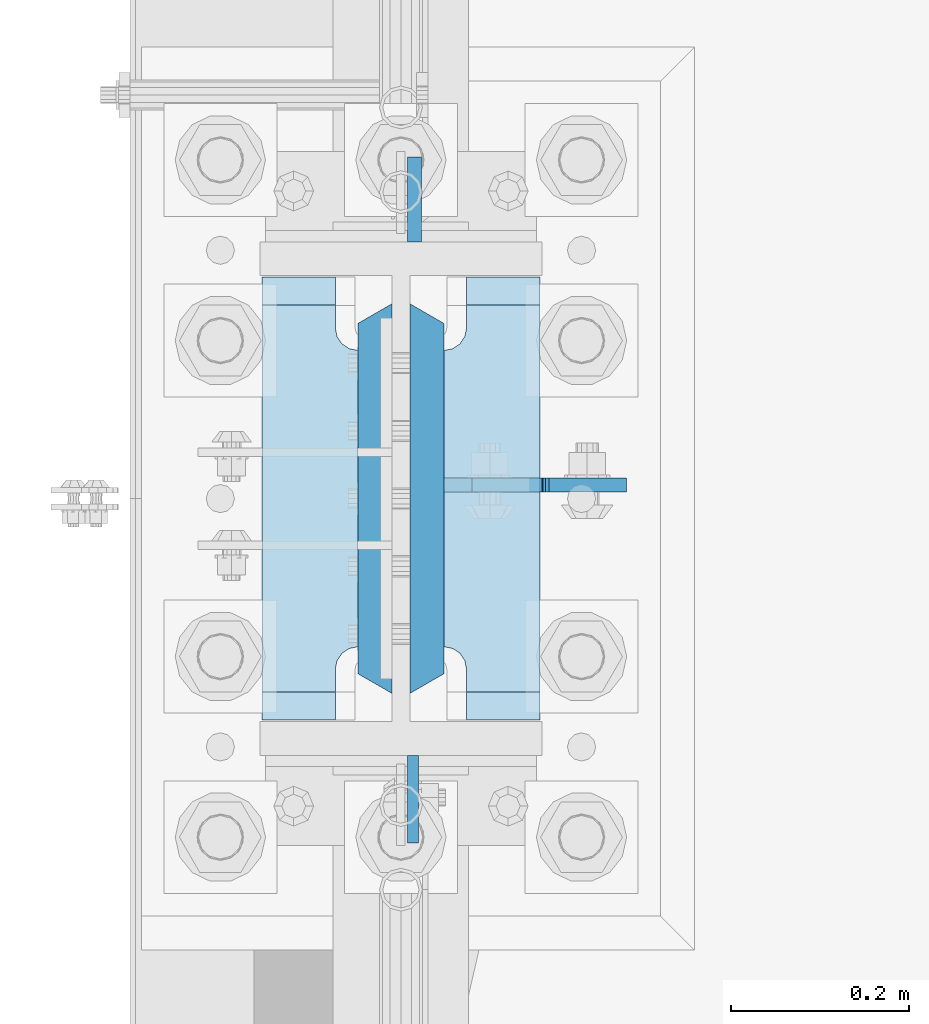
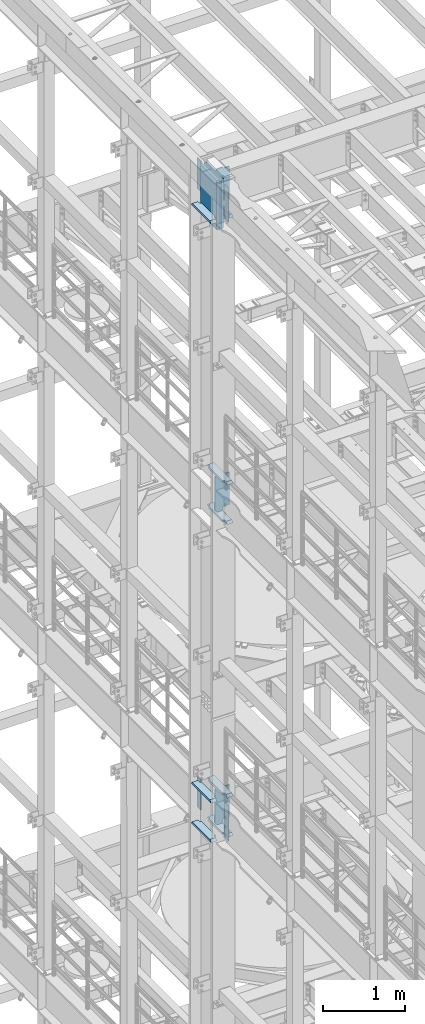
# One storey, part 1691 of 1876: 17 plates, 2 elements without a shape of their own.
"""IFC2X3 building model written with IfcOpenShell, lengths in millimetres."""

import ifcopenshell
import ifcopenshell.guid

model = None  # the IFC model being written
_history = None  # IfcOwnerHistory: only IFC2X3 demands one
_inside = {}  # id of a spatial element -> (the spatial element, [elements in it])
_under = {}  # id of a project, library or spatial element -> (it, [spatial elements below it])
_declared = {}  # id of a project -> (the project, [libraries it declares])
_typed = {}  # id of a type object -> (the type object, [elements of that type])
_made_of = {}  # id of a material, layer set ... -> (it, [elements and type objects made of it])


def new_model(schema):
    """Start an empty IFC model of exactly this schema.

    Asked for "IFC4X3", IfcOpenShell would pick the latest addendum, in which some entities
    have other attributes; the version numbers below select the first issue.
    IFC2X3 requires an IfcOwnerHistory on every rooted entity: one is made here for all.
    """
    global model, _history
    if schema == "IFC4X3":
        model = ifcopenshell.file(schema_version=(4, 3, 0, 0))
    else:
        model = ifcopenshell.file(schema=schema)
    _inside.clear()
    _under.clear()
    _declared.clear()
    _typed.clear()
    _made_of.clear()
    _history = None
    if model.schema == "IFC2X3":
        org = make("IfcOrganization", Name="unknown")
        user = make(
            "IfcPersonAndOrganization",
            ThePerson=make("IfcPerson", FamilyName="unknown"),
            TheOrganization=org,
        )
        app = make(
            "IfcApplication",
            ApplicationDeveloper=org,
            Version="unknown",
            ApplicationFullName="unknown",
            ApplicationIdentifier="unknown",
        )
        _history = make(
            "IfcOwnerHistory",
            OwningUser=user,
            OwningApplication=app,
            ChangeAction="ADDED",
            CreationDate=0,
        )
    return model


def make(cls, **values):
    """One entity of the class cls with the attributes given. An attribute that is None is left unset."""
    return model.create_entity(
        cls, **{name: value for name, value in values.items() if value is not None}
    )


def rooted(cls, **values):
    """An entity with a GlobalId (a new one), such as an element, a storey or a relation."""
    return make(cls, GlobalId=ifcopenshell.guid.new(), OwnerHistory=_history, **values)


def si_unit(unit_type, name, prefix=None):
    """IfcSIUnit, for example si_unit("LENGTHUNIT", "METRE", prefix="MILLI")."""
    return make("IfcSIUnit", UnitType=unit_type, Prefix=prefix, Name=name)


def assignment(units):
    """IfcUnitAssignment: the units of a project."""
    return None if units is None else make("IfcUnitAssignment", Units=units)


def point(xyz):
    """IfcCartesianPoint."""
    return None if xyz is None else make("IfcCartesianPoint", Coordinates=xyz)


def direction(xyz):
    """IfcDirection."""
    return None if xyz is None else make("IfcDirection", DirectionRatios=xyz)


def frame(location, z_axis=None, x_axis=None):
    """IfcAxis2Placement3D, a coordinate frame: its origin and axes. An axis left out is left unset."""
    return make(
        "IfcAxis2Placement3D",
        Location=point(location),
        Axis=direction(z_axis),
        RefDirection=direction(x_axis),
    )


def origin_with_axes():
    """The frame at (0, 0, 0) with the z axis (0, 0, 1) and the x axis (1, 0, 0) written out."""
    return frame((0.0, 0.0, 0.0), z_axis=(0.0, 0.0, 1.0), x_axis=(1.0, 0.0, 0.0))


def place(relative_to, where):
    """IfcLocalPlacement: puts the frame where relative to a parent placement (None: the world)."""
    return make(
        "IfcLocalPlacement", PlacementRelTo=relative_to, RelativePlacement=where
    )


def context(
    kind, dimensions, precision=None, world=None, true_north=None, identifier=None
):
    """IfcGeometricRepresentationContext, for example the 3D "Model" context."""
    return make(
        "IfcGeometricRepresentationContext",
        ContextIdentifier=identifier,
        ContextType=kind,
        CoordinateSpaceDimension=dimensions,
        Precision=precision,
        WorldCoordinateSystem=world,
        TrueNorth=true_north,
    )


def subcontext(parent, identifier, kind, view, scale=None):
    """IfcGeometricRepresentationSubContext, for example "Body" below "Model"."""
    return make(
        "IfcGeometricRepresentationSubContext",
        ContextIdentifier=identifier,
        ContextType=kind,
        ParentContext=parent,
        TargetScale=scale,
        TargetView=view,
    )


def project(units=None, contexts=None):
    """IfcProject with its units and contexts."""
    return rooted(
        "IfcProject",
        Name="project",
        RepresentationContexts=contexts,
        UnitsInContext=assignment(units),
    )


def spatial(cls, under=None, at=None, **own):
    """A site, building, storey or space (cls), placed at a placement, below another one or the project."""
    s = rooted(cls, ObjectPlacement=at, **own)
    if under is not None:
        _under.setdefault(under.id(), (under, []))[1].append(s)
    return s


def faces_of(points, faces, orient=None, outer=None):
    """IfcFace entities. A face is a list of loops; a loop is a list of indices into points, from 0.

    orient and outer hold one flag for each loop. By default every Orientation is true, the
    first loop of a face is its IfcFaceOuterBound and the others are IfcFaceBound.
    """
    made = []
    for i, loops in enumerate(faces):
        bounds = []
        for j, loop in enumerate(loops):
            is_outer = j == 0 if outer is None else outer[i][j]
            bounds.append(
                make(
                    "IfcFaceOuterBound" if is_outer else "IfcFaceBound",
                    Bound=make("IfcPolyLoop", Polygon=[points[k] for k in loop]),
                    Orientation=True if orient is None else orient[i][j],
                )
            )
        made.append(make("IfcFace", Bounds=bounds))
    return made


def faceted_brep(points, faces, orient=None, outer=None, voids=None):
    """IfcFacetedBrep: a solid bounded by flat faces; with voids (closed shells), ...WithVoids."""
    shared = [point(p) for p in points]
    hull = make("IfcClosedShell", CfsFaces=faces_of(shared, faces, orient, outer))
    if voids is None:
        return make("IfcFacetedBrep", Outer=hull)
    return make(
        "IfcFacetedBrepWithVoids",
        Outer=hull,
        Voids=[
            make(cls, CfsFaces=faces_of(shared, fs, o, b)) for cls, fs, o, b in voids
        ],
    )


def shape(context_of_items, identifier, shape_type, items):
    """IfcShapeRepresentation: the items that make up one representation, for example the "Body"."""
    return make(
        "IfcShapeRepresentation",
        ContextOfItems=context_of_items,
        RepresentationIdentifier=identifier,
        RepresentationType=shape_type,
        Items=items,
    )


def material(Name=None, Category=None):
    """IfcMaterial."""
    return make("IfcMaterial", Name=Name, Category=Category)


def made_of(thing, what):
    """Note that an element or type object is made of a material, layer set ...; save() writes the relation."""
    if what is not None:
        _made_of.setdefault(what.id(), (what, []))[1].append(thing)
    return thing


def type_object(cls, material=None, **own):
    """A type object (cls), such as IfcWallType, which elements share."""
    return made_of(rooted(cls, **own), material)


def element(
    cls,
    number,
    at=None,
    inside=None,
    cuts=None,
    type_object=None,
    material=None,
    context=None,
    identifier="Body",
    shape_type=None,
    held_by="IfcProductDefinitionShape",
    body=None,
    shapes=None,
    **own,
):
    """One element of the class cls, such as IfcWall. Its Tag is "e" and its number.

    at: its placement. inside: the storey or other place that contains it. cuts: it is an
    opening in that element (IfcRelVoidsElement). A single representation is given by context,
    identifier, shape_type and body (its items); several are given by shapes. held_by: the class
    of the entity that holds the representations. save() writes the other relations.
    """
    e = rooted(cls, Tag="e%d" % number, ObjectPlacement=at, **own)
    if body is not None:
        shapes = [shape(context, identifier, shape_type, body)]
    if shapes is not None:
        e.Representation = make(held_by, Representations=shapes)
    if inside is not None:
        _inside.setdefault(inside.id(), (inside, []))[1].append(e)
    if cuts is not None:
        rooted(
            "IfcRelVoidsElement", RelatingBuildingElement=cuts, RelatedOpeningElement=e
        )
    if type_object is not None:
        _typed.setdefault(type_object.id(), (type_object, []))[1].append(e)
    return made_of(e, material)


def aggregate(whole, parts):
    """IfcRelAggregates: a whole, such as a stair, and the parts it consists of."""
    return rooted("IfcRelAggregates", RelatingObject=whole, RelatedObjects=parts)


def save(model, path):
    """Write the relations noted so far, then the file.

    IfcRelAggregates (storeys below a building ...), IfcRelContainedInSpatialStructure (elements
    in a storey), IfcRelDefinesByType, IfcRelAssociatesMaterial and IfcRelDeclares: one each for
    every whole, place, type object, material and project.
    """
    for whole, parts in _under.values():
        aggregate(whole, parts)
    for where, things in _inside.values():
        rooted(
            "IfcRelContainedInSpatialStructure",
            RelatedElements=things,
            RelatingStructure=where,
        )
    for kind, things in _typed.values():
        rooted("IfcRelDefinesByType", RelatedObjects=things, RelatingType=kind)
    for what, things in _made_of.values():
        rooted("IfcRelAssociatesMaterial", RelatedObjects=things, RelatingMaterial=what)
    for by, libraries in _declared.values():
        rooted("IfcRelDeclares", RelatingContext=by, RelatedDefinitions=libraries)
    model.write(path)


model = new_model("IFC2X3")

# Units and contexts
model_context = context("Model", 3, precision=1e-05, world=origin_with_axes())
body_context = subcontext(model_context, "Body", "Model", "MODEL_VIEW")
ifc_project = project(units=[si_unit("LENGTHUNIT", "METRE", prefix="MILLI"), si_unit("AREAUNIT", "SQUARE_METRE"), si_unit("VOLUMEUNIT", "CUBIC_METRE"), si_unit("MASSUNIT", "GRAM", prefix="KILO"), si_unit("TIMEUNIT", "SECOND"), si_unit("PLANEANGLEUNIT", "RADIAN"), si_unit("SOLIDANGLEUNIT", "STERADIAN"), si_unit("THERMODYNAMICTEMPERATUREUNIT", "DEGREE_CELSIUS"), si_unit("LUMINOUSINTENSITYUNIT", "LUMEN")], contexts=[model_context])

# Site, building, storey
site_placement = place(None, origin_with_axes())
site = spatial("IfcSite", under=ifc_project, at=site_placement, CompositionType="ELEMENT")
building_placement = place(site_placement, origin_with_axes())
building = spatial("IfcBuilding", under=site, at=building_placement, Name="Undefined", CompositionType="ELEMENT")
storey_placement = place(building_placement, origin_with_axes())
storey = spatial("IfcBuildingStorey", under=building, at=storey_placement, Name="Undefined", CompositionType="ELEMENT", Elevation=0.0)

# Assembly, plate
assembly_1_placement = place(storey_placement, origin_with_axes())
assembly_1 = element("IfcElementAssembly", 1, at=assembly_1_placement, inside=storey, Name="COLUMN", AssemblyPlace="NOTDEFINED", PredefinedType="RIGID_FRAME")
ifc_material_1 = material(Name="STEEL/A572-50")
plate_type_1 = type_object("IfcPlateType", PredefinedType="NOTDEFINED")
plate_1_placement = place(assembly_1_placement, frame((13.493000125885, 7331.075, 22501.225), z_axis=(0.0, -1.0, 0.0), x_axis=(0.0, 0.0, -1.0)))
plate_1 = element("IfcPlate", 2, at=plate_1_placement, type_object=plate_type_1, material=ifc_material_1, Name="PLATE", context=body_context, shape_type="Brep", body=[
    faceted_brep([(0.0, -6.35000000000036, 0.0), (0.0, -6.34999999999991, 98.4250030517578), (0.0, 6.34999999999991, 98.4250030517578), (0.0, 6.35000000000036, 0.0), (514.349975585938, -6.35000000000036, 98.4250030517578), (514.349975585938, 6.35000000000036, 98.4250030517578), (514.349975585938, -6.35000000000036, 0.0), (514.349975585938, 6.35000000000036, 0.0)], [[[0, 1, 2, 3]], [[1, 4, 5, 2]], [[4, 6, 7, 5]], [[6, 0, 3, 7]], [[5, 7, 3, 2]], [[6, 4, 1, 0]]]),
])

assembly_2_placement = place(storey_placement, origin_with_axes())
assembly_2 = element("IfcElementAssembly", 3, at=assembly_2_placement, inside=storey, Name="COLUMN", AssemblyPlace="NOTDEFINED", PredefinedType="RIGID_FRAME")
plate_2_placement = place(assembly_2_placement, frame((13.493000125885, 7331.075, 13255.625), z_axis=(0.0, -1.0, 0.0), x_axis=(0.0, 0.0, -1.0)))
plate_2 = element("IfcPlate", 4, at=plate_2_placement, type_object=plate_type_1, material=ifc_material_1, Name="PLATE", context=body_context, shape_type="Brep", body=[
    faceted_brep([(0.0, -6.35000000000036, 0.0), (0.0, -6.34999999999991, 98.4250030517578), (0.0, 6.34999999999991, 98.4250030517578), (0.0, 6.35000000000036, 0.0), (514.349975585938, -6.35000000000036, 98.4250030517578), (514.349975585938, 6.35000000000036, 98.4250030517578), (514.349975585938, -6.35000000000036, 0.0), (514.349975585938, 6.35000000000036, 0.0)], [[[0, 1, 2, 3]], [[1, 4, 5, 2]], [[4, 6, 7, 5]], [[6, 0, 3, 7]], [[5, 7, 3, 2]], [[6, 4, 1, 0]]]),
])

# Plate
ifc_material_2 = material(Name="STEEL/A572-GR.50")
plate_type_2 = type_object("IfcPlateType", PredefinedType="NOTDEFINED")
plate_3_placement = place(assembly_1_placement, frame((29.3687499999999, 7839.075, 22523.45), z_axis=(0.0, -1.0, 0.0), x_axis=(0.0, 0.0, -1.0)))
plate_3 = element("IfcPlate", 5, at=plate_3_placement, type_object=plate_type_2, material=ifc_material_2, Name="PLATE", context=body_context, shape_type="Brep", body=[
    faceted_brep([(0.0, 19.0500000000002, 416.152954742277), (0.0, -19.0500000000002, 438.149993896484), (742.950012207031, -19.0500000000002, 438.149993896484), (742.950012207031, 19.0500000000002, 416.152954742277), (742.950012207031, 19.0500000000002, 21.9970452577325), (0.0, 19.0500000000002, 21.9970452577367), (0.0, -19.0500000000002, 0.0), (742.950012207031, -19.0500000000002, 0.0)], [[[0, 1, 2, 3]], [[0, 3, 4, 5]], [[1, 0, 5, 6]], [[2, 1, 6, 7]], [[3, 2, 7, 4]], [[6, 5, 4, 7]]]),
])

plate_4_placement = place(assembly_1_placement, frame((-29.3687499999999, 7839.075, 22523.45), z_axis=(0.0, -1.0, 0.0), x_axis=(0.0, 0.0, -1.0)))
plate_4 = element("IfcPlate", 6, at=plate_4_placement, type_object=plate_type_2, material=ifc_material_2, Name="PLATE", context=body_context, shape_type="Brep", body=[
    faceted_brep([(0.0, -19.0500000000002, 416.152954749452), (742.950012207031, -19.0500000000002, 416.152954749372), (742.950012207031, 19.0500000000002, 438.149993896484), (0.0, 19.0500000000002, 438.149993896484), (742.950012207031, -19.0500000000002, 21.9970452506512), (742.950012207031, 19.0500000000002, 0.0), (-9.09494701772928e-13, 19.05, -1.81898940354586e-12), (0.0, -19.0500000000002, 21.9970452506512)], [[[0, 1, 2, 3]], [[2, 1, 4, 5]], [[3, 2, 5, 6]], [[0, 3, 6, 7]], [[1, 0, 7, 4]], [[6, 5, 4, 7]]]),
])

plate_type_3 = type_object("IfcPlateType", PredefinedType="NOTDEFINED")
plate_5_placement = place(assembly_1_placement, frame((15.080500125885, 7908.925, 22491.7), z_axis=(0.0, 1.0, 0.0), x_axis=(0.0, 0.0, -1.0)))
plate_5 = element("IfcPlate", 7, at=plate_5_placement, type_object=plate_type_3, material=ifc_material_1, Name="PLATE", context=body_context, shape_type="Brep", body=[
    faceted_brep([(0.0, -7.9375, 0.0), (0.0, -7.9375, 95.25), (0.0, 7.9375, 95.25), (0.0, 7.9375, 0.0), (457.200012207031, -7.9375, 95.25), (457.200012207031, 7.9375, 95.25), (457.200012207031, -7.9375, 0.0), (457.200012207031, 7.9375, 0.0)], [[[0, 1, 2, 3]], [[1, 4, 5, 2]], [[4, 6, 7, 5]], [[6, 0, 3, 7]], [[5, 7, 3, 2]], [[6, 4, 1, 0]]]),
])

ifc_material_3 = material(Name="STEEL/A36")
plate_6_placement = place(assembly_2_placement, frame((15.080500125885, 7908.925, 13246.1), z_axis=(0.0, 1.0, 0.0), x_axis=(0.0, 0.0, -1.0)))
plate_6 = element("IfcPlate", 8, at=plate_6_placement, type_object=plate_type_3, material=ifc_material_3, Name="PLATE", context=body_context, shape_type="Brep", body=[
    faceted_brep([(0.0, -7.9375, 0.0), (0.0, -7.9375, 95.25), (0.0, 7.9375, 95.25), (0.0, 7.9375, 0.0), (457.200012207031, -7.9375, 95.25), (457.200012207031, 7.9375, 95.25), (457.200012207031, -7.9375, 0.0), (457.200012207031, 7.9375, 0.0)], [[[0, 1, 2, 3]], [[1, 4, 5, 2]], [[4, 6, 7, 5]], [[6, 0, 3, 7]], [[5, 7, 3, 2]], [[6, 4, 1, 0]]]),
])

plate_type_4 = type_object("IfcPlateType", PredefinedType="NOTDEFINED")
plate_7_placement = place(assembly_1_placement, frame((156.36875, 7370.7625, 17376.775012207), z_axis=(0.0, 1.0, 0.0), x_axis=(-1.0, 0.0, 0.0)))
plate_7 = element("IfcPlate", 9, at=plate_7_placement, type_object=plate_type_4, material=ifc_material_1, Name="PLATE", context=body_context, shape_type="Brep", body=[
    faceted_brep([(82.5499973297119, -15.875, 498.475006103516), (82.5499973297119, 15.875, 467.025007631571), (0.0, 15.875, 467.025007631571), (0.0, -15.875, 498.475006103516), (82.5499973297119, 15.875, 31.449998471945), (82.5499973297119, -15.875, 0.0), (0.0, -15.875, 0.0), (0.0, 15.875, 31.449998471945), (82.5499973297119, 15.875, 57.1500034332275), (82.5499973297119, -15.875, 57.1500034332275), (84.4834571748879, -15.875, 66.8701624693188), (84.4834571748879, 15.875, 66.8701624693188), (89.9894849758439, -15.875, 75.1105154056261), (89.9894849758439, 15.875, 75.1105154056261), (98.2298379121512, -15.875, 80.616543206582), (98.2298379121512, 15.875, 80.616543206582), (107.949996948242, -15.875, 82.5500030517578), (107.949996948242, 15.875, 82.5500030517578), (107.949996948242, -15.875, 415.925003051758), (107.949996948242, 15.875, 415.925003051758), (98.2298379121512, -15.875, 417.858462896934), (98.2298379121512, 15.875, 417.858462896934), (89.9894849758439, -15.875, 423.36449069789), (89.9894849758439, 15.875, 423.36449069789), (84.483457174887, -15.875, 431.604843634197), (84.483457174887, 15.875, 431.604843634197), (82.5499973297119, -15.875, 441.325002670288), (82.5499973297119, 15.875, 441.325002670288)], [[[0, 1, 2, 3]], [[4, 5, 6, 7]], [[8, 9, 5, 4]], [[10, 9, 8, 11]], [[12, 10, 11, 13]], [[14, 12, 13, 15]], [[16, 14, 15, 17]], [[18, 16, 17, 19]], [[20, 18, 19, 21]], [[22, 20, 21, 23]], [[24, 22, 23, 25]], [[26, 24, 25, 27]], [[6, 5, 9, 10, 12, 14, 16, 18, 20, 22, 24, 26, 0, 3]], [[7, 6, 3, 2]], [[27, 25, 23, 21, 19, 17, 15, 13, 11, 8, 4, 7, 2, 1]], [[26, 27, 1, 0]]]),
])

plate_8_placement = place(assembly_1_placement, frame((156.36875, 7370.7625, 17967.325), z_axis=(0.0, 1.0, 0.0), x_axis=(-1.0, 0.0, 0.0)))
plate_8 = element("IfcPlate", 10, at=plate_8_placement, type_object=plate_type_4, material=ifc_material_1, Name="PLATE", context=body_context, shape_type="Brep", body=[
    faceted_brep([(82.5499973297119, -15.875, 498.475006103516), (82.5499973297119, 15.875, 467.025007631571), (0.0, 15.875, 467.025007631571), (0.0, -15.875, 498.475006103516), (82.5499973297119, 15.875, 31.449998471945), (82.5499973297119, -15.875, 0.0), (0.0, -15.875, 0.0), (0.0, 15.875, 31.449998471945), (82.5499973297119, 15.875, 57.1500034332275), (82.5499973297119, -15.875, 57.1500034332275), (84.4834571748879, -15.875, 66.8701624693188), (84.4834571748879, 15.875, 66.8701624693188), (89.9894849758439, -15.875, 75.1105154056261), (89.9894849758439, 15.875, 75.1105154056261), (98.2298379121512, -15.875, 80.616543206582), (98.2298379121512, 15.875, 80.616543206582), (107.949996948242, -15.875, 82.5500030517578), (107.949996948242, 15.875, 82.5500030517578), (107.949996948242, -15.875, 415.925003051758), (107.949996948242, 15.875, 415.925003051758), (98.2298379121512, -15.875, 417.858462896934), (98.2298379121512, 15.875, 417.858462896934), (89.9894849758439, -15.875, 423.36449069789), (89.9894849758439, 15.875, 423.36449069789), (84.483457174887, -15.875, 431.604843634197), (84.483457174887, 15.875, 431.604843634197), (82.5499973297119, -15.875, 441.325002670288), (82.5499973297119, 15.875, 441.325002670288)], [[[0, 1, 2, 3]], [[4, 5, 6, 7]], [[8, 9, 5, 4]], [[10, 9, 8, 11]], [[12, 10, 11, 13]], [[14, 12, 13, 15]], [[16, 14, 15, 17]], [[18, 16, 17, 19]], [[20, 18, 19, 21]], [[22, 20, 21, 23]], [[24, 22, 23, 25]], [[26, 24, 25, 27]], [[6, 5, 9, 10, 12, 14, 16, 18, 20, 22, 24, 26, 0, 3]], [[7, 6, 3, 2]], [[27, 25, 23, 21, 19, 17, 15, 13, 11, 8, 4, 7, 2, 1]], [[26, 27, 1, 0]]]),
])

plate_9_placement = place(assembly_1_placement, frame((-48.41875, 7370.7625, 21948.775012207), z_axis=(0.0, 1.0, 0.0), x_axis=(-1.0, 0.0, 0.0)))
plate_9 = element("IfcPlate", 11, at=plate_9_placement, type_object=plate_type_4, material=ifc_material_1, Name="PLATE", context=body_context, shape_type="Brep", body=[
    faceted_brep([(107.949996948242, -15.875, 498.475006103516), (107.949996948242, 15.875, 467.025007631571), (25.3999996185303, 15.875, 467.025007631571), (25.3999996185303, -15.875, 498.475006103516), (23.4665397733561, -15.875, 431.604843634198), (25.3999996185303, -15.875, 441.325002670288), (25.3999996185303, 15.875, 441.325002670288), (23.4665397733561, 15.875, 431.604843634198), (17.9605119724001, -15.875, 423.36449069789), (17.9605119724001, 15.875, 423.36449069789), (9.72015903609281, -15.875, 417.858462896934), (9.72015903609281, 15.875, 417.858462896934), (0.0, -15.875, 415.925003051758), (0.0, 15.875, 415.925003051758), (0.0, -15.875, 82.5500030517578), (0.0, 15.875, 82.5500030517578), (9.72015903609099, -15.875, 80.616543206582), (9.72015903609099, 15.875, 80.616543206582), (17.9605119723983, -15.875, 75.1105154056258), (17.9605119723983, 15.875, 75.1105154056258), (23.4665397733552, -15.875, 66.8701624693183), (23.4665397733552, 15.875, 66.8701624693183), (25.3999996185303, -15.875, 57.1500034332275), (25.3999996185303, 15.875, 57.1500034332275), (25.3999996185303, 15.875, 31.449998471945), (25.3999996185303, -15.875, 0.0), (107.949996948242, 15.875, 31.449998471945), (107.949996948242, -15.875, 0.0)], [[[0, 1, 2, 3]], [[4, 5, 6, 7]], [[8, 4, 7, 9]], [[10, 8, 9, 11]], [[12, 10, 11, 13]], [[14, 12, 13, 15]], [[16, 14, 15, 17]], [[18, 16, 17, 19]], [[20, 18, 19, 21]], [[22, 20, 21, 23]], [[22, 23, 24, 25]], [[26, 27, 25, 24]], [[5, 4, 8, 10, 12, 14, 16, 18, 20, 22, 25, 27, 0, 3]], [[6, 5, 3, 2]], [[26, 24, 23, 21, 19, 17, 15, 13, 11, 9, 7, 6, 2, 1]], [[27, 26, 1, 0]]]),
])

plate_10_placement = place(assembly_1_placement, frame((156.36875, 7370.7625, 21948.775012207), z_axis=(0.0, 1.0, 0.0), x_axis=(-1.0, 0.0, 0.0)))
plate_10 = element("IfcPlate", 12, at=plate_10_placement, type_object=plate_type_4, material=ifc_material_1, Name="PLATE", context=body_context, shape_type="Brep", body=[
    faceted_brep([(82.5499973297119, -15.875, 498.475006103516), (82.5499973297119, 15.875, 467.025007631571), (0.0, 15.875, 467.025007631571), (0.0, -15.875, 498.475006103516), (82.5499973297119, 15.875, 31.449998471945), (82.5499973297119, -15.875, 0.0), (0.0, -15.875, 0.0), (0.0, 15.875, 31.449998471945), (82.5499973297119, 15.875, 57.1500034332275), (82.5499973297119, -15.875, 57.1500034332275), (84.4834571748879, -15.875, 66.8701624693188), (84.4834571748879, 15.875, 66.8701624693188), (89.9894849758439, -15.875, 75.1105154056261), (89.9894849758439, 15.875, 75.1105154056261), (98.2298379121512, -15.875, 80.616543206582), (98.2298379121512, 15.875, 80.616543206582), (107.949996948242, -15.875, 82.5500030517578), (107.949996948242, 15.875, 82.5500030517578), (107.949996948242, -15.875, 415.925003051758), (107.949996948242, 15.875, 415.925003051758), (98.2298379121512, -15.875, 417.858462896934), (98.2298379121512, 15.875, 417.858462896934), (89.9894849758439, -15.875, 423.36449069789), (89.9894849758439, 15.875, 423.36449069789), (84.483457174887, -15.875, 431.604843634197), (84.483457174887, 15.875, 431.604843634197), (82.5499973297119, -15.875, 441.325002670288), (82.5499973297119, 15.875, 441.325002670288)], [[[0, 1, 2, 3]], [[4, 5, 6, 7]], [[8, 9, 5, 4]], [[10, 9, 8, 11]], [[12, 10, 11, 13]], [[14, 12, 13, 15]], [[16, 14, 15, 17]], [[18, 16, 17, 19]], [[20, 18, 19, 21]], [[22, 20, 21, 23]], [[24, 22, 23, 25]], [[26, 24, 25, 27]], [[6, 5, 9, 10, 12, 14, 16, 18, 20, 22, 24, 26, 0, 3]], [[7, 6, 3, 2]], [[27, 25, 23, 21, 19, 17, 15, 13, 11, 8, 4, 7, 2, 1]], [[26, 27, 1, 0]]]),
])

plate_11_placement = place(assembly_2_placement, frame((-48.41875, 7370.7625, 12703.175012207), z_axis=(0.0, 1.0, 0.0), x_axis=(-1.0, 0.0, 0.0)))
plate_11 = element("IfcPlate", 13, at=plate_11_placement, type_object=plate_type_4, material=ifc_material_1, Name="PLATE", context=body_context, shape_type="Brep", body=[
    faceted_brep([(107.949996948242, -15.875, 498.475006103516), (107.949996948242, 15.875, 467.025007631571), (25.3999996185303, 15.875, 467.025007631571), (25.3999996185303, -15.875, 498.475006103516), (23.4665397733561, -15.875, 431.604843634198), (25.3999996185303, -15.875, 441.325002670288), (25.3999996185303, 15.875, 441.325002670288), (23.4665397733561, 15.875, 431.604843634198), (17.9605119724001, -15.875, 423.36449069789), (17.9605119724001, 15.875, 423.36449069789), (9.72015903609281, -15.875, 417.858462896934), (9.72015903609281, 15.875, 417.858462896934), (0.0, -15.875, 415.925003051758), (0.0, 15.875, 415.925003051758), (0.0, -15.875, 82.5500030517578), (0.0, 15.875, 82.5500030517578), (9.72015903609099, -15.875, 80.616543206582), (9.72015903609099, 15.875, 80.616543206582), (17.9605119723983, -15.875, 75.1105154056258), (17.9605119723983, 15.875, 75.1105154056258), (23.4665397733552, -15.875, 66.8701624693183), (23.4665397733552, 15.875, 66.8701624693183), (25.3999996185303, -15.875, 57.1500034332275), (25.3999996185303, 15.875, 57.1500034332275), (25.3999996185303, 15.875, 31.449998471945), (25.3999996185303, -15.875, 0.0), (107.949996948242, 15.875, 31.449998471945), (107.949996948242, -15.875, 0.0)], [[[0, 1, 2, 3]], [[4, 5, 6, 7]], [[8, 4, 7, 9]], [[10, 8, 9, 11]], [[12, 10, 11, 13]], [[14, 12, 13, 15]], [[16, 14, 15, 17]], [[18, 16, 17, 19]], [[20, 18, 19, 21]], [[22, 20, 21, 23]], [[22, 23, 24, 25]], [[26, 27, 25, 24]], [[5, 4, 8, 10, 12, 14, 16, 18, 20, 22, 25, 27, 0, 3]], [[6, 5, 3, 2]], [[26, 24, 23, 21, 19, 17, 15, 13, 11, 9, 7, 6, 2, 1]], [[27, 26, 1, 0]]]),
])

plate_12_placement = place(assembly_2_placement, frame((-48.41875, 7370.7625, 13293.725), z_axis=(0.0, 1.0, 0.0), x_axis=(-1.0, 0.0, 0.0)))
plate_12 = element("IfcPlate", 14, at=plate_12_placement, type_object=plate_type_4, material=ifc_material_1, Name="PLATE", context=body_context, shape_type="Brep", body=[
    faceted_brep([(107.949996948242, -15.875, 498.475006103516), (107.949996948242, 15.875, 467.025007631571), (25.3999996185303, 15.875, 467.025007631571), (25.3999996185303, -15.875, 498.475006103516), (23.4665397733561, -15.875, 431.604843634198), (25.3999996185303, -15.875, 441.325002670288), (25.3999996185303, 15.875, 441.325002670288), (23.4665397733561, 15.875, 431.604843634198), (17.9605119724001, -15.875, 423.36449069789), (17.9605119724001, 15.875, 423.36449069789), (9.72015903609281, -15.875, 417.858462896934), (9.72015903609281, 15.875, 417.858462896934), (0.0, -15.875, 415.925003051758), (0.0, 15.875, 415.925003051758), (0.0, -15.875, 82.5500030517578), (0.0, 15.875, 82.5500030517578), (9.72015903609099, -15.875, 80.616543206582), (9.72015903609099, 15.875, 80.616543206582), (17.9605119723983, -15.875, 75.1105154056258), (17.9605119723983, 15.875, 75.1105154056258), (23.4665397733552, -15.875, 66.8701624693183), (23.4665397733552, 15.875, 66.8701624693183), (25.3999996185303, -15.875, 57.1500034332275), (25.3999996185303, 15.875, 57.1500034332275), (25.3999996185303, 15.875, 31.449998471945), (25.3999996185303, -15.875, 0.0), (107.949996948242, 15.875, 31.449998471945), (107.949996948242, -15.875, 0.0)], [[[0, 1, 2, 3]], [[4, 5, 6, 7]], [[8, 4, 7, 9]], [[10, 8, 9, 11]], [[12, 10, 11, 13]], [[14, 12, 13, 15]], [[16, 14, 15, 17]], [[18, 16, 17, 19]], [[20, 18, 19, 21]], [[22, 20, 21, 23]], [[22, 23, 24, 25]], [[26, 27, 25, 24]], [[5, 4, 8, 10, 12, 14, 16, 18, 20, 22, 25, 27, 0, 3]], [[6, 5, 3, 2]], [[26, 24, 23, 21, 19, 17, 15, 13, 11, 9, 7, 6, 2, 1]], [[27, 26, 1, 0]]]),
])

plate_13_placement = place(assembly_2_placement, frame((156.36875, 7370.7625, 12703.175012207), z_axis=(0.0, 1.0, 0.0), x_axis=(-1.0, 0.0, 0.0)))
plate_13 = element("IfcPlate", 15, at=plate_13_placement, type_object=plate_type_4, material=ifc_material_1, Name="PLATE", context=body_context, shape_type="Brep", body=[
    faceted_brep([(82.5499973297119, -15.875, 498.475006103516), (82.5499973297119, 15.875, 467.025007631571), (0.0, 15.875, 467.025007631571), (0.0, -15.875, 498.475006103516), (82.5499973297119, 15.875, 31.449998471945), (82.5499973297119, -15.875, 0.0), (0.0, -15.875, 0.0), (0.0, 15.875, 31.449998471945), (82.5499973297119, 15.875, 57.1500034332275), (82.5499973297119, -15.875, 57.1500034332275), (84.4834571748879, -15.875, 66.8701624693188), (84.4834571748879, 15.875, 66.8701624693188), (89.9894849758439, -15.875, 75.1105154056261), (89.9894849758439, 15.875, 75.1105154056261), (98.2298379121512, -15.875, 80.616543206582), (98.2298379121512, 15.875, 80.616543206582), (107.949996948242, -15.875, 82.5500030517578), (107.949996948242, 15.875, 82.5500030517578), (107.949996948242, -15.875, 415.925003051758), (107.949996948242, 15.875, 415.925003051758), (98.2298379121512, -15.875, 417.858462896934), (98.2298379121512, 15.875, 417.858462896934), (89.9894849758439, -15.875, 423.36449069789), (89.9894849758439, 15.875, 423.36449069789), (84.483457174887, -15.875, 431.604843634197), (84.483457174887, 15.875, 431.604843634197), (82.5499973297119, -15.875, 441.325002670288), (82.5499973297119, 15.875, 441.325002670288)], [[[0, 1, 2, 3]], [[4, 5, 6, 7]], [[8, 9, 5, 4]], [[10, 9, 8, 11]], [[12, 10, 11, 13]], [[14, 12, 13, 15]], [[16, 14, 15, 17]], [[18, 16, 17, 19]], [[20, 18, 19, 21]], [[22, 20, 21, 23]], [[24, 22, 23, 25]], [[26, 24, 25, 27]], [[6, 5, 9, 10, 12, 14, 16, 18, 20, 22, 24, 26, 0, 3]], [[7, 6, 3, 2]], [[27, 25, 23, 21, 19, 17, 15, 13, 11, 8, 4, 7, 2, 1]], [[26, 27, 1, 0]]]),
])

plate_14_placement = place(assembly_2_placement, frame((156.36875, 7370.7625, 13293.725), z_axis=(0.0, 1.0, 0.0), x_axis=(-1.0, 0.0, 0.0)))
plate_14 = element("IfcPlate", 16, at=plate_14_placement, type_object=plate_type_4, material=ifc_material_1, Name="PLATE", context=body_context, shape_type="Brep", body=[
    faceted_brep([(82.5499973297119, -15.875, 498.475006103516), (82.5499973297119, 15.875, 467.025007631571), (0.0, 15.875, 467.025007631571), (0.0, -15.875, 498.475006103516), (82.5499973297119, 15.875, 31.449998471945), (82.5499973297119, -15.875, 0.0), (0.0, -15.875, 0.0), (0.0, 15.875, 31.449998471945), (82.5499973297119, 15.875, 57.1500034332275), (82.5499973297119, -15.875, 57.1500034332275), (84.4834571748879, -15.875, 66.8701624693188), (84.4834571748879, 15.875, 66.8701624693188), (89.9894849758439, -15.875, 75.1105154056261), (89.9894849758439, 15.875, 75.1105154056261), (98.2298379121512, -15.875, 80.616543206582), (98.2298379121512, 15.875, 80.616543206582), (107.949996948242, -15.875, 82.5500030517578), (107.949996948242, 15.875, 82.5500030517578), (107.949996948242, -15.875, 415.925003051758), (107.949996948242, 15.875, 415.925003051758), (98.2298379121512, -15.875, 417.858462896934), (98.2298379121512, 15.875, 417.858462896934), (89.9894849758439, -15.875, 423.36449069789), (89.9894849758439, 15.875, 423.36449069789), (84.483457174887, -15.875, 431.604843634197), (84.483457174887, 15.875, 431.604843634197), (82.5499973297119, -15.875, 441.325002670288), (82.5499973297119, 15.875, 441.325002670288)], [[[0, 1, 2, 3]], [[4, 5, 6, 7]], [[8, 9, 5, 4]], [[10, 9, 8, 11]], [[12, 10, 11, 13]], [[14, 12, 13, 15]], [[16, 14, 15, 17]], [[18, 16, 17, 19]], [[20, 18, 19, 21]], [[22, 20, 21, 23]], [[24, 22, 23, 25]], [[26, 24, 25, 27]], [[6, 5, 9, 10, 12, 14, 16, 18, 20, 22, 24, 26, 0, 3]], [[7, 6, 3, 2]], [[27, 25, 23, 21, 19, 17, 15, 13, 11, 8, 4, 7, 2, 1]], [[26, 27, 1, 0]]]),
])

plate_type_5 = type_object("IfcPlateType", PredefinedType="NOTDEFINED")
plate_15_placement = place(assembly_1_placement, frame((48.41875, 7635.08125, 17951.45), z_axis=(1.0, 0.0, 0.0), x_axis=(0.0, 0.0, -1.0)))
plate_15 = element("IfcPlate", 17, at=plate_15_placement, type_object=plate_type_5, material=ifc_material_3, Name="PLATE", context=body_context, shape_type="Brep", body=[
    faceted_brep([(501.650012207032, -7.9375, 205.581252728631), (501.650012207032, -7.9375, 123.031246757509), (501.650012207032, 7.9375, 123.031246757509), (501.650012207032, 7.9375, 205.581253051758), (502.61674212962, -7.9375, 118.171167239463), (502.61674212962, 7.9375, 118.171167239463), (505.369756030097, -7.9375, 114.050990771309), (505.369756030097, 7.9375, 114.050990771309), (509.489932498251, -7.9375, 111.297976870831), (509.489932498251, 7.9375, 111.297976870831), (514.350012016297, -7.9375, 110.331246948243), (514.350012016297, 7.9375, 110.331246948243), (558.799987792969, -7.9375, 110.331246948243), (558.799987792969, 7.9375, 110.331246948243), (19.0499992370605, -7.9375, 205.58125), (19.0499992370605, 7.9375, 205.581253051758), (19.0499992370605, 7.9375, 123.031249809265), (19.0499992370605, -7.9375, 123.031249809265), (18.083269314473, 7.9375, 118.17117029122), (18.083269314473, -7.9375, 118.17117029122), (15.3302554139955, 7.9375, 114.050993823066), (15.3302554139955, -7.9375, 114.050993823066), (11.2100789458418, 7.9375, 111.297979922588), (11.2100789458418, -7.9375, 111.297979922588), (6.34999942779541, 7.9375, 110.33125), (6.34999942779541, -7.9375, 110.33125), (0.0, 7.9375, 110.33125), (0.0, -7.9375, 110.33125), (0.0, 7.93749999999999, 31.75), (0.0, -7.93749999999998, 31.75), (31.75, -7.93749999999998, 0.0), (31.75, 7.93749999999999, 0.0), (527.049987792969, -7.93749999999998, 0.0), (527.049987792969, 7.93749999999999, 0.0), (558.799987792969, -7.93749999999998, 31.75), (558.799987792969, 7.93749999999999, 31.75)], [[[0, 1, 2, 3]], [[4, 5, 2, 1]], [[6, 7, 5, 4]], [[8, 9, 7, 6]], [[10, 11, 9, 8]], [[12, 13, 11, 10]], [[14, 15, 16, 17]], [[17, 16, 18, 19]], [[19, 18, 20, 21]], [[21, 20, 22, 23]], [[23, 22, 24, 25]], [[25, 24, 26, 27]], [[28, 29, 27, 26]], [[30, 29, 28, 31]], [[32, 30, 31, 33]], [[34, 32, 33, 35]], [[8, 6, 4, 1, 0, 14, 17, 19, 21, 23, 25, 27, 29, 30, 32, 34, 12, 10]], [[15, 14, 0, 3]], [[35, 33, 31, 28, 26, 24, 22, 20, 18, 16, 15, 3, 2, 5, 7, 9, 11, 13]], [[34, 35, 13, 12]]]),
])

plate_16_placement = place(assembly_1_placement, frame((48.41875, 7635.08125, 22523.45), z_axis=(1.0, 0.0, 0.0), x_axis=(0.0, 0.0, -1.0)))
plate_16 = element("IfcPlate", 18, at=plate_16_placement, type_object=plate_type_5, material=ifc_material_3, Name="PLATE", context=body_context, shape_type="Brep", body=[
    faceted_brep([(501.650012207032, -7.9375, 205.581252728631), (501.650012207032, -7.9375, 123.031246757509), (501.650012207032, 7.9375, 123.031246757509), (501.650012207032, 7.9375, 205.581253051758), (502.61674212962, -7.9375, 118.171167239463), (502.61674212962, 7.9375, 118.171167239463), (505.369756030097, -7.9375, 114.050990771309), (505.369756030097, 7.9375, 114.050990771309), (509.489932498251, -7.9375, 111.297976870831), (509.489932498251, 7.9375, 111.297976870831), (514.350012016297, -7.9375, 110.331246948243), (514.350012016297, 7.9375, 110.331246948243), (533.39998855591, -7.9375, 110.331253051758), (533.39998855591, 7.9375, 110.331253051758), (558.799987792969, -7.9375, 110.331246948243), (558.799987792969, 7.9375, 110.331246948243), (19.0499992370605, -7.9375, 205.58125), (19.0499992370605, 7.9375, 205.581253051758), (19.0499992370605, 7.9375, 123.031249809265), (19.0499992370605, -7.9375, 123.031249809265), (18.083269314473, 7.9375, 118.17117029122), (18.083269314473, -7.9375, 118.17117029122), (15.3302554139955, 7.9375, 114.050993823066), (15.3302554139955, -7.9375, 114.050993823066), (11.2100789458418, 7.9375, 111.297979922588), (11.2100789458418, -7.9375, 111.297979922588), (6.34999942779541, 7.9375, 110.33125), (6.34999942779541, -7.9375, 110.33125), (0.0, 7.9375, 110.33125), (0.0, -7.9375, 110.33125), (0.0, 7.93749999999999, 31.75), (0.0, -7.93749999999998, 31.75), (31.75, -7.93749999999998, 0.0), (31.75, 7.93749999999999, 0.0), (527.049987792969, -7.93749999999998, 0.0), (527.049987792969, 7.93749999999999, 0.0), (558.799987792969, -7.93749999999998, 31.75), (558.799987792969, 7.93749999999999, 31.75)], [[[0, 1, 2, 3]], [[4, 5, 2, 1]], [[6, 7, 5, 4]], [[8, 9, 7, 6]], [[10, 11, 9, 8]], [[12, 13, 11, 10]], [[14, 15, 13, 12]], [[16, 17, 18, 19]], [[19, 18, 20, 21]], [[21, 20, 22, 23]], [[23, 22, 24, 25]], [[25, 24, 26, 27]], [[27, 26, 28, 29]], [[30, 31, 29, 28]], [[32, 31, 30, 33]], [[34, 32, 33, 35]], [[36, 34, 35, 37]], [[10, 8, 6, 4, 1, 0, 16, 19, 21, 23, 25, 27, 29, 31, 32, 34, 36, 14, 12]], [[17, 16, 0, 3]], [[37, 35, 33, 30, 28, 26, 24, 22, 20, 18, 17, 3, 2, 5, 7, 9, 11, 13, 15]], [[36, 37, 15, 14]]]),
])

aggregate(assembly_1, [plate_7, plate_8, plate_15, plate_9, plate_10, plate_16, plate_3, plate_4, plate_1, plate_5])

plate_17_placement = place(assembly_2_placement, frame((48.4187500000004, 7635.08125, 13277.85), z_axis=(1.0, 0.0, 0.0), x_axis=(0.0, 0.0, -1.0)))
plate_17 = element("IfcPlate", 19, at=plate_17_placement, type_object=plate_type_5, material=ifc_material_3, Name="PLATE", context=body_context, shape_type="Brep", body=[
    faceted_brep([(501.650012207032, -7.9375, 205.581252728631), (501.650012207032, -7.9375, 123.031246757509), (501.650012207032, 7.9375, 123.031246757509), (501.650012207032, 7.9375, 205.581253051758), (502.61674212962, -7.9375, 118.171167239463), (502.61674212962, 7.9375, 118.171167239463), (505.369756030097, -7.9375, 114.050990771309), (505.369756030097, 7.9375, 114.050990771309), (509.489932498251, -7.9375, 111.297976870831), (509.489932498251, 7.9375, 111.297976870831), (514.350012016297, -7.9375, 110.331246948243), (514.350012016297, 7.9375, 110.331246948243), (558.799987792969, -7.9375, 110.331246948243), (558.799987792969, 7.9375, 110.331246948243), (19.0499992370605, -7.9375, 205.58125), (19.0499992370605, 7.9375, 205.581253051758), (19.0499992370605, 7.9375, 123.031249809265), (19.0499992370605, -7.9375, 123.031249809265), (18.083269314473, 7.9375, 118.17117029122), (18.083269314473, -7.9375, 118.17117029122), (15.3302554139955, 7.9375, 114.050993823066), (15.3302554139955, -7.9375, 114.050993823066), (11.2100789458418, 7.9375, 111.297979922588), (11.2100789458418, -7.9375, 111.297979922588), (6.34999942779541, 7.9375, 110.33125), (6.34999942779541, -7.9375, 110.33125), (0.0, 7.9375, 110.33125), (0.0, -7.9375, 110.33125), (0.0, 7.93749999999999, 31.75), (0.0, -7.93749999999998, 31.75), (31.75, -7.93749999999998, 0.0), (31.75, 7.93749999999999, 0.0), (527.049987792969, -7.93749999999998, 0.0), (527.049987792969, 7.93749999999999, 0.0), (558.799987792969, -7.93749999999998, 31.75), (558.799987792969, 7.93749999999999, 31.75)], [[[0, 1, 2, 3]], [[4, 5, 2, 1]], [[6, 7, 5, 4]], [[8, 9, 7, 6]], [[10, 11, 9, 8]], [[12, 13, 11, 10]], [[14, 15, 16, 17]], [[17, 16, 18, 19]], [[19, 18, 20, 21]], [[21, 20, 22, 23]], [[23, 22, 24, 25]], [[25, 24, 26, 27]], [[28, 29, 27, 26]], [[30, 29, 28, 31]], [[32, 30, 31, 33]], [[34, 32, 33, 35]], [[8, 6, 4, 1, 0, 14, 17, 19, 21, 23, 25, 27, 29, 30, 32, 34, 12, 10]], [[15, 14, 0, 3]], [[35, 33, 31, 28, 26, 24, 22, 20, 18, 16, 15, 3, 2, 5, 7, 9, 11, 13]], [[34, 35, 13, 12]]]),
])

aggregate(assembly_2, [plate_2, plate_6, plate_11, plate_12, plate_13, plate_14, plate_17])

save(model, "model.ifc")
